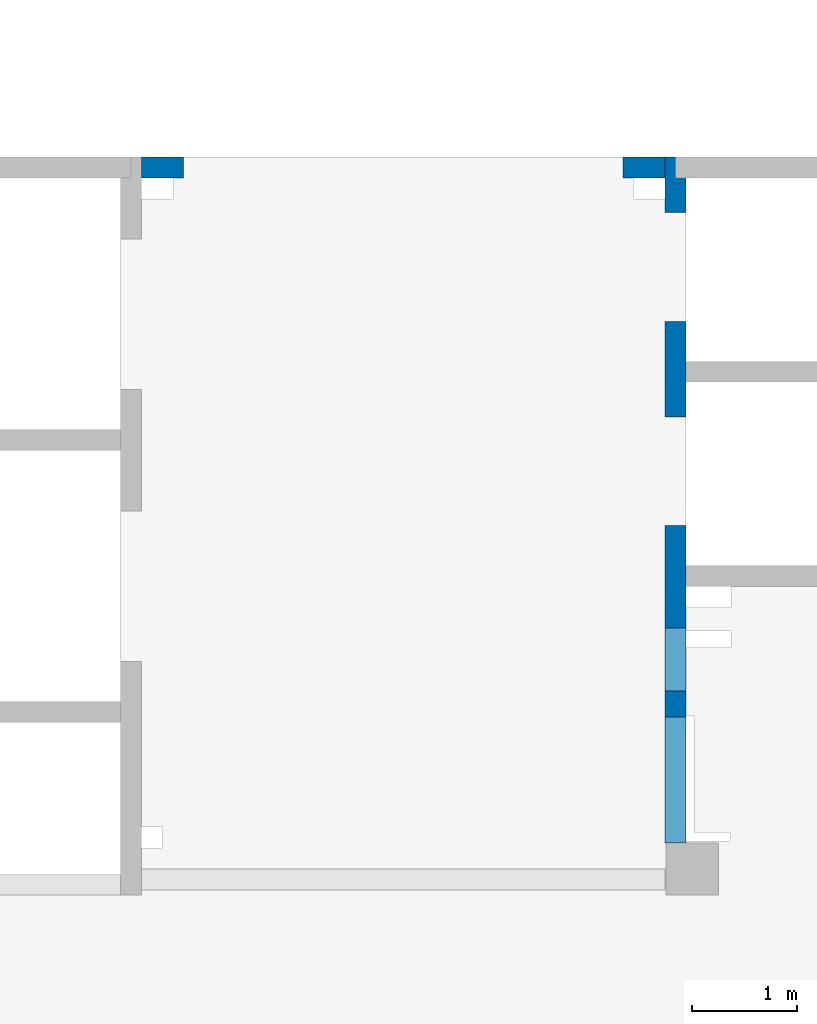
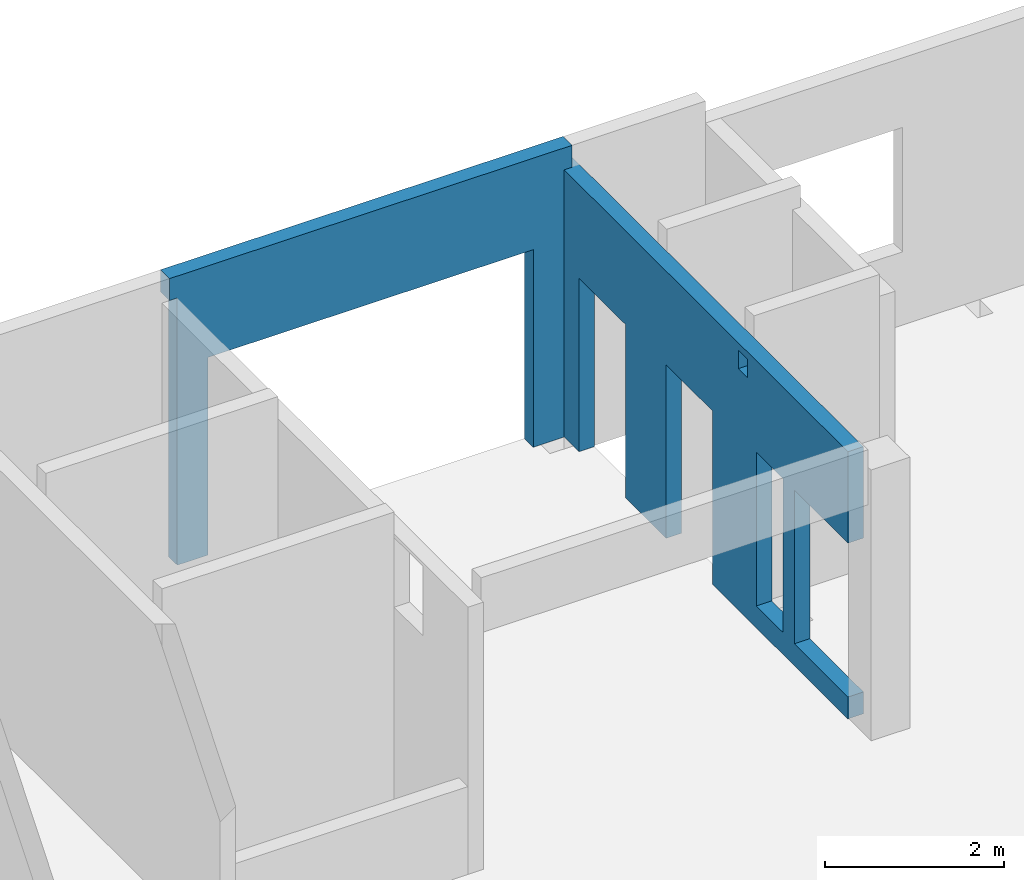
# One storey, part 5 of 7: 2 walls, 6 openings.
"""IFC4 building model written with IfcOpenShell, lengths in millimetres."""

from ifc_helpers import new_model, entity, si_unit, converted_unit, derived_unit, direction, frame, origin, place, context, subcontext, project, spatial, indexed_curve, outline, extrude, polygons, material, type_object, element, save


model = new_model("IFC4")

# Units and contexts
model_context = context("Model", 3, precision=0.01, world=origin(), true_north=direction((6.12303176911189e-17, 1.0)))
plan_context = context("Plan", 3, precision=0.01, world=origin(), true_north=direction((6.12303176911189e-17, 1.0)))
body_context = subcontext(model_context, "Body", "Model", "MODEL_VIEW")
ifc_project = project(units=[si_unit("LENGTHUNIT", "METRE", prefix="MILLI"), si_unit("AREAUNIT", "SQUARE_METRE"), si_unit("VOLUMEUNIT", "CUBIC_METRE"), converted_unit("PLANEANGLEUNIT", "DEGREE", entity("IfcRatioMeasure", 0.0174532925199433), si_unit("PLANEANGLEUNIT", "RADIAN"), dimensions=[0, 0, 0, 0, 0, 0, 0]), si_unit("MASSUNIT", "GRAM", prefix="KILO"), derived_unit("MASSDENSITYUNIT", [(si_unit("MASSUNIT", "GRAM", prefix="KILO"), 1), (si_unit("LENGTHUNIT", "METRE"), -3)]), derived_unit("MOMENTOFINERTIAUNIT", [(si_unit("LENGTHUNIT", "METRE"), 4)]), si_unit("TIMEUNIT", "SECOND"), si_unit("FREQUENCYUNIT", "HERTZ"), si_unit("THERMODYNAMICTEMPERATUREUNIT", "DEGREE_CELSIUS"), derived_unit("THERMALTRANSMITTANCEUNIT", [(si_unit("MASSUNIT", "GRAM", prefix="KILO"), 1), (si_unit("THERMODYNAMICTEMPERATUREUNIT", "KELVIN"), -1), (si_unit("TIMEUNIT", "SECOND"), -3)]), derived_unit("VOLUMETRICFLOWRATEUNIT", [(si_unit("LENGTHUNIT", "METRE"), 3), (si_unit("TIMEUNIT", "SECOND"), -1)]), derived_unit("MASSFLOWRATEUNIT", [(si_unit("MASSUNIT", "GRAM", prefix="KILO"), 1), (si_unit("TIMEUNIT", "SECOND"), -1)]), derived_unit("ROTATIONALFREQUENCYUNIT", [(si_unit("TIMEUNIT", "SECOND"), -1)]), si_unit("ELECTRICCURRENTUNIT", "AMPERE"), si_unit("ELECTRICVOLTAGEUNIT", "VOLT"), si_unit("POWERUNIT", "WATT"), si_unit("FORCEUNIT", "NEWTON", prefix="KILO"), si_unit("ILLUMINANCEUNIT", "LUX"), si_unit("LUMINOUSFLUXUNIT", "LUMEN"), si_unit("LUMINOUSINTENSITYUNIT", "CANDELA"), derived_unit("USERDEFINED", [(si_unit("MASSUNIT", "GRAM", prefix="KILO"), -1), (si_unit("LENGTHUNIT", "METRE"), -2), (si_unit("TIMEUNIT", "SECOND"), 3), (si_unit("LUMINOUSFLUXUNIT", "LUMEN"), 1)]), derived_unit("LINEARVELOCITYUNIT", [(si_unit("LENGTHUNIT", "METRE"), 1), (si_unit("TIMEUNIT", "SECOND"), -1)]), si_unit("PRESSUREUNIT", "PASCAL"), derived_unit("USERDEFINED", [(si_unit("LENGTHUNIT", "METRE"), -2), (si_unit("MASSUNIT", "GRAM", prefix="KILO"), 1), (si_unit("TIMEUNIT", "SECOND"), -2)]), derived_unit("LINEARFORCEUNIT", [(si_unit("MASSUNIT", "GRAM", prefix="KILO"), 1), (si_unit("LENGTHUNIT", "METRE"), 1), (si_unit("TIMEUNIT", "SECOND"), -2), (si_unit("LENGTHUNIT", "METRE"), -1)]), derived_unit("PLANARFORCEUNIT", [(si_unit("MASSUNIT", "GRAM", prefix="KILO"), 1), (si_unit("LENGTHUNIT", "METRE"), 1), (si_unit("TIMEUNIT", "SECOND"), -2), (si_unit("LENGTHUNIT", "METRE"), -2)])], contexts=[model_context, plan_context])

# Site, building, storey
site_placement = place(None, origin())
site = spatial("IfcSite", under=ifc_project, at=site_placement, CompositionType="ELEMENT")
building_placement = place(site_placement, origin())
building = spatial("IfcBuilding", under=site, at=building_placement, CompositionType="ELEMENT")
storey_placement = place(building_placement, frame((0.0, 0.0, 12000.0)))
storey = spatial("IfcBuildingStorey", under=building, at=storey_placement, CompositionType="ELEMENT", Elevation=12000.0)

# Wall, openings
ifc_material = material()
wall_type = type_object("IfcWallType", PredefinedType="STANDARD")
wall_1_placement = place(storey_placement, frame((16000.0002685547, 20499.9998657227, -150.0), z_axis=(0.0, 0.0, 1.0), x_axis=(0.0, -1.0, 0.0)))
wall_1 = element("IfcWall", 1, at=wall_1_placement, inside=storey, type_object=wall_type, material=ifc_material, PredefinedType="NOTDEFINED", context=body_context, shape_type="Tessellation", body=[
    polygons([(4100.00063936683, -100.000000000321, 3550.0), (4300.00063936683, -100.00000000032, 3550.0), (4300.00063936683, -100.00000000032, 3300.00000000001), (4100.00063936683, -100.000000000321, 3300.00000000001), (4500.00063936683, -99.9999999999995, 2399.99999999999), (5100.00063936683, -100.000000000001, 2399.99999999999), (5100.00063936683, -100.000000000001, 300.000000000001), (4500.00063936683, -99.9999999999995, 300.000000000001), (6550.00048980714, -99.9999999999982, 3650.0), (400.000000000009, -99.9999999999998, 3650.0), (200.000000000002, -100.0, 3650.0), (0.0, -100.0, 3650.0), (0.0, -100.0, 49.9999999999973), (200.000000000002, -100.0, 49.9999999999973), (200.000000000002, -100.0, 0.0), (529.999999999996, -99.9999999999995, 0.0), (529.999999999996, -99.9999999999995, 2369.99999999804), (1570.0, -100.000000000002, 2369.99999999804), (1570.0, -100.000000000002, 0.0), (2480.0, -100.000000000001, 0.0), (2480.0, -100.000000000001, 2369.99999999804), (3519.99999999999, -100.000000000001, 2369.99999999804), (3519.99999999999, -100.000000000001, 0.0), (6550.00048980714, -99.9999999999982, 0.0), (6550.00048980714, -99.9999999999982, 300.000000000001), (5350.00048980714, -100.0, 300.000000000001), (5350.00048980714, -100.0, 2399.99999999999), (6550.00048980714, -99.9999999999982, 2399.99999999999), (4300.00063936683, 100.0, 3550.0), (4100.00063936683, 99.9999999999999, 3550.0), (4100.00063936683, 99.9999999999999, 3300.00000000001), (4300.00063936683, 100.0, 3300.00000000001), (5100.00063936683, 99.9999999999994, 2399.99999999999), (4500.00063936683, 99.9999999999984, 2399.99999999998), (4500.00063936683, 99.9999999999984, 300.000000000001), (5100.00063936683, 99.9999999999994, 300.000000000001), (0.0, 99.9999999999996, 3650.0), (200.000000000002, 99.9999999999999, 3650.0), (3900.00063936685, 99.9999999999995, 3650.0), (4100.00063936685, 99.9999999999999, 3650.0), (4300.00063936685, 100.0, 3650.0), (4525.00063936685, 100.000000000001, 3650.0), (4685.00063936685, 99.9999999999987, 3650.0), (5340.00063936685, 99.9999999999998, 3650.0), (6530.00063936685, 99.9999999999996, 3650.0), (6550.00048980714, 99.9999999999996, 3650.0), (6550.00048980714, 99.9999999999996, 2399.99999999999), (5350.00048980714, 99.9999999999998, 2399.99999999998), (5350.00048980714, 99.9999999999998, 300.000000000001), (6550.00048980714, 99.9999999999996, 300.000000000001), (6550.00048980714, 99.9999999999996, 0.0), (4100.00063936683, 99.9999999999999, 0.0), (3900.00063936683, 99.9999999999995, 0.0), (3519.99999999999, 99.9999999999989, 0.0), (3519.99999999999, 99.9999999999989, 2369.99999999804), (2480.0, 100.000000000002, 2369.99999999804), (2480.0, 100.000000000002, 0.0), (1570.0, 100.0, 0.0), (1570.0, 100.0, 2369.99999999804), (529.999999999996, 100.0, 2369.99999999804), (529.999999999996, 100.0, 0.0), (200.000000000002, 99.9999999999999, 0.0), (200.000000000002, 99.9999999999999, 49.9999999999973), (0.0, 99.9999999999996, 49.9999999999973), (200.000000000002, 9.88347789881356e-13, 0.0), (0.0, 6.56688670961758e-13, 3650.0)], [[[9, 10, 11, 12, 13, 14, 15, 16, 17, 18, 19, 20, 21, 22, 23, 24, 25, 26, 27, 28], [1, 2, 3, 4], [5, 6, 7, 8]], [[37, 38, 39, 40, 41, 42, 43, 44, 45, 46, 47, 48, 49, 50, 51, 52, 53, 54, 55, 56, 57, 58, 59, 60, 61, 62, 63, 64], [29, 30, 31, 32], [33, 34, 35, 36]], [[16, 15, 65, 62, 61]], [[24, 51, 50, 25]], [[12, 11, 10, 9, 46, 45, 44, 43, 42, 41, 40, 39, 38, 37, 66]], [[2, 1, 30, 29]], [[2, 29, 32, 3]], [[3, 32, 31, 4]], [[30, 1, 4, 31]], [[33, 6, 5, 34]], [[34, 5, 8, 35]], [[35, 8, 7, 36]], [[6, 33, 36, 7]], [[27, 48, 47, 28]], [[48, 27, 26, 49]], [[49, 26, 25, 50]], [[55, 22, 21, 56]], [[56, 21, 20, 57]], [[22, 55, 54, 23]], [[59, 18, 17, 60]], [[60, 17, 16, 61]], [[18, 59, 58, 19]], [[15, 14, 63, 62, 65]], [[13, 12, 66, 37, 64]], [[64, 63, 14, 13]], [[46, 9, 28, 47]], [[57, 20, 19, 58]], [[51, 24, 23, 54, 53, 52]]], closed=True),
])
opening_1_placement = place(wall_1_placement, frame((20499.9998657227, -16000.0002685547, 150.0), z_axis=(0.0, 0.0, 1.0), x_axis=(0.0, 1.0, 0.0)))
element("IfcOpeningElement", 2, at=opening_1_placement, cuts=wall_1, PredefinedType="OPENING", context=body_context, shape_type="SweptSolid", body=[
    extrude(outline(indexed_curve([(-1049.99999999999, -600.0), (1049.99999999999, -600.0), (1049.99999999999, 600.0), (-1049.99999999999, 600.0), (-1049.99999999999, -600.0)], self_intersect=False)), frame((15800.0002685547, 14549.9993759155, 1200.0), z_axis=(1.0, 0.0, 0.0), x_axis=(0.0, 0.0, -1.0)), (0.0, 0.0, 1.0), 400.000000001943),
])
opening_2_placement = place(wall_1_placement, frame((20499.9998657227, -16000.0002685547, 150.0), z_axis=(0.0, 0.0, 1.0), x_axis=(0.0, 1.0, 0.0)))
element("IfcOpeningElement", 3, at=opening_2_placement, cuts=wall_1, PredefinedType="OPENING", context=body_context, shape_type="SweptSolid", body=[
    extrude(outline(indexed_curve([(-1184.99999999902, -520.000000000001), (1184.99999999902, -520.000000000001), (1184.99999999902, 519.999999999999), (-1184.99999999902, 519.999999999999), (-1184.99999999902, -520.000000000001)], self_intersect=False)), frame((15800.0002685547, 17499.9998657227, 1035.0), z_axis=(1.0, 0.0, 0.0), x_axis=(0.0, 0.0, -1.0)), (0.0, 0.0, 1.0), 400.000000001943),
])
opening_3_placement = place(wall_1_placement, frame((20499.9998657227, -16000.0002685547, 150.0), z_axis=(0.0, 0.0, 1.0), x_axis=(0.0, 1.0, 0.0)))
element("IfcOpeningElement", 4, at=opening_3_placement, cuts=wall_1, PredefinedType="OPENING", context=body_context, shape_type="SweptSolid", body=[
    extrude(outline(indexed_curve([(-1184.99999999902, -519.999999999999), (1184.99999999902, -519.999999999999), (1184.99999999902, 520.000000000001), (-1184.99999999902, 520.000000000001), (-1184.99999999902, -519.999999999999)], self_intersect=False)), frame((15800.0002685547, 19449.9998657227, 1035.0), z_axis=(1.0, 0.0, 0.0), x_axis=(0.0, 0.0, -1.0)), (0.0, 0.0, 1.0), 400.000000001943),
])
opening_4_placement = place(wall_1_placement, frame((20499.9998657227, -16000.0002685547, 150.0), z_axis=(0.0, 0.0, 1.0), x_axis=(0.0, 1.0, 0.0)))
element("IfcOpeningElement", 5, at=opening_4_placement, cuts=wall_1, PredefinedType="OPENING", context=body_context, shape_type="SweptSolid", body=[
    extrude(outline(indexed_curve([(-100.000000000001, -124.999999999993), (99.9999999999989, -124.999999999993), (99.9999999999989, 124.999999999993), (-100.000000000001, 124.999999999993), (-100.000000000001, -124.999999999993)], self_intersect=False)), frame((15900.0002685537, 16299.9992263558, 3275.0), z_axis=(1.0, 0.0, 0.0), x_axis=(0.0, -1.0, 0.0)), (0.0, 0.0, 1.0), 200.000000000962),
])
opening_5_placement = place(wall_1_placement, frame((20499.9998657227, -16000.0002685547, 150.0), z_axis=(0.0, 0.0, 1.0), x_axis=(0.0, 1.0, 0.0)))
element("IfcOpeningElement", 6, at=opening_5_placement, cuts=wall_1, PredefinedType="OPENING", context=body_context, shape_type="SweptSolid", body=[
    extrude(outline(indexed_curve([(-1049.99999999999, -300.000000000001), (1049.99999999999, -300.000000000001), (1049.99999999999, 299.999999999999), (-1049.99999999999, 299.999999999999), (-1049.99999999999, -300.000000000001)], self_intersect=False)), frame((15800.0002685547, 15699.9992263558, 1200.0), z_axis=(1.0, 0.0, 0.0), x_axis=(0.0, 0.0, -1.0)), (0.0, 0.0, 1.0), 400.000000001943),
])

# Wall, opening
wall_2_placement = place(storey_placement, frame((10800.0002685547, 20399.9998657227, -150.0)))
wall_2 = element("IfcWall", 7, at=wall_2_placement, inside=storey, type_object=wall_type, material=ifc_material, PredefinedType="NOTDEFINED", context=body_context, shape_type="Tessellation", body=[
    polygons([(5200.00000000001, -100.000000000003, 3950.0), (5100.00000000001, -100.000000000003, 3950.0), (100.000000000001, -100.000000000003, 3950.0), (-4.99784381508401e-13, -100.000000000003, 3950.0), (-4.99784381508401e-13, -100.000000000003, 3900.0), (-4.99784381508401e-13, -100.000000000003, 3650.0), (100.000000000001, -100.000000000003, 3650.0), (100.000000000001, -100.000000000003, 0.0), (499.999999999992, -99.9999999999989, 0.0), (499.999999999994, -100.000000000003, 2699.99999999804), (4699.99999999999, -100.000000000003, 2699.99999999804), (4699.99999999999, -100.000000000003, 0.0), (5100.00000000001, -100.000000000003, 0.0), (5100.00000000001, -100.000000000003, 3650.0), (5200.00000000001, -100.000000000003, 3650.0), (5200.00000000001, -100.000000000003, 3900.0), (-1.16616415338434e-12, 99.9999999999989, 3950.0), (99.9999999999999, 99.9999999999989, 3950.0), (5100.0, 99.9999999999989, 3950.0), (5200.00000000001, 99.9999999999989, 3950.0), (5200.00000000001, 99.9999999999989, 3900.0), (5200.00000000001, 99.9999999999989, 3650.0), (5100.0, 99.9999999999989, 3650.0), (5100.0, 99.9999999999989, 49.9999999999973), (5100.0, 99.9999999999989, 0.0), (4699.99999999999, 99.9999999999989, 0.0), (4699.99999999999, 99.9999999999989, 2699.99999999804), (499.999999999993, 100.000000000003, 2699.99999999804), (499.999999999993, 100.000000000003, 0.0), (99.9999999999999, 99.9999999999989, 0.0), (99.9999999999999, 99.9999999999989, 49.9999999999973), (99.9999999999999, 99.9999999999989, 3650.0), (-1.16616415338434e-12, 99.9999999999989, 3650.0), (-1.16616415338434e-12, 99.9999999999989, 3900.0)], [[[1, 2, 3, 4, 5, 6, 7, 8, 9, 10, 11, 12, 13, 14, 15, 16]], [[17, 18, 19, 20, 21, 22, 23, 24, 25, 26, 27, 28, 29, 30, 31, 32, 33, 34]], [[8, 30, 29, 9]], [[4, 3, 2, 1, 20, 19, 18, 17]], [[10, 28, 27, 11]], [[11, 27, 26, 12]], [[28, 10, 9, 29]], [[20, 1, 16, 15, 22, 21]], [[13, 25, 24, 23, 14]], [[6, 33, 32, 7]], [[4, 17, 34, 33, 6, 5]], [[30, 8, 7, 32, 31]], [[22, 15, 14, 23]], [[25, 13, 12, 26]]], closed=True),
])
opening_6_placement = place(wall_2_placement, frame((-10800.0002685547, -20399.9998657227, 150.0)))
element("IfcOpeningElement", 8, at=opening_6_placement, cuts=wall_2, PredefinedType="OPENING", context=body_context, shape_type="SweptSolid", body=[
    extrude(outline(indexed_curve([(-2100.0, -1349.99999999902), (2100.0, -1349.99999999902), (2100.0, 1349.99999999902), (-2100.0, 1349.99999999902), (-2100.0, -1349.99999999902)], self_intersect=False)), frame((13400.0002685547, 20199.9998657207, 1200.0), z_axis=(0.0, 1.0, 0.0), x_axis=(1.0, 0.0, 0.0)), (0.0, 0.0, 1.0), 400.000000001945),
])

save(model, "model.ifc")
